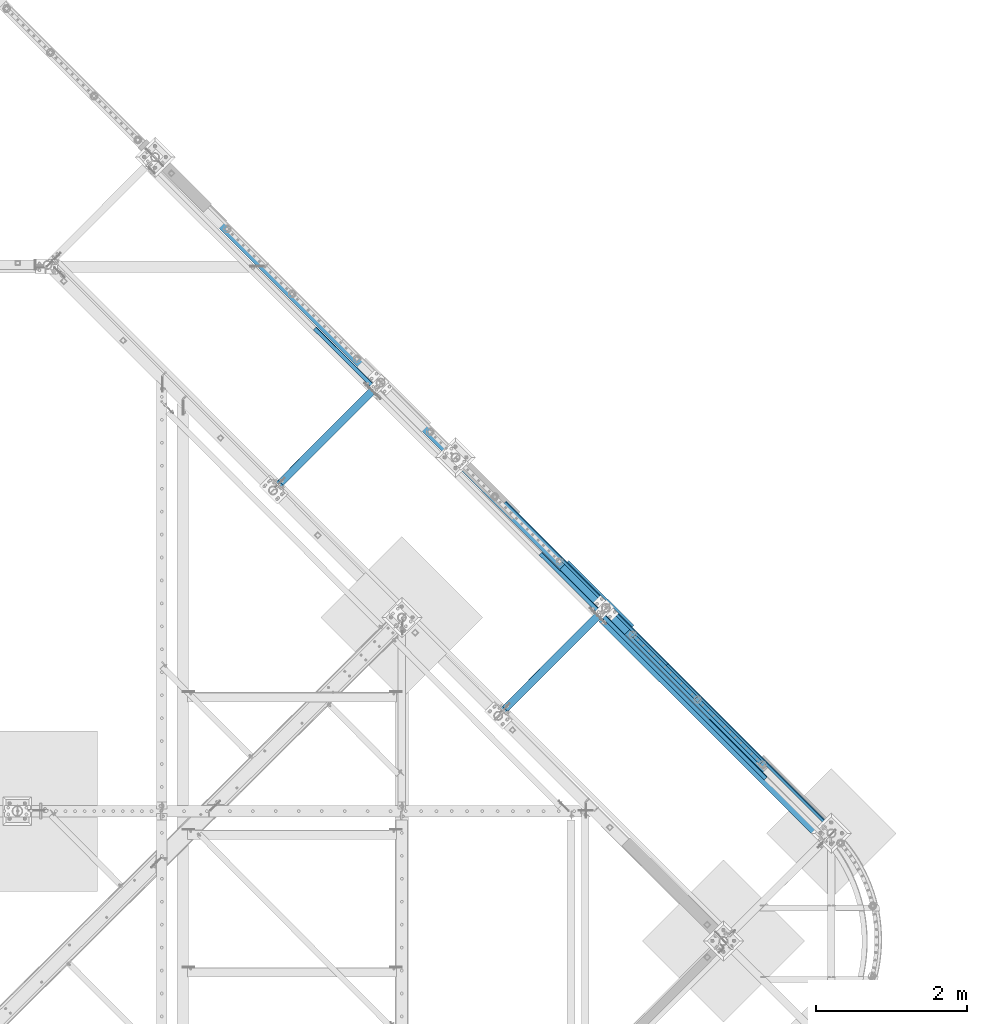
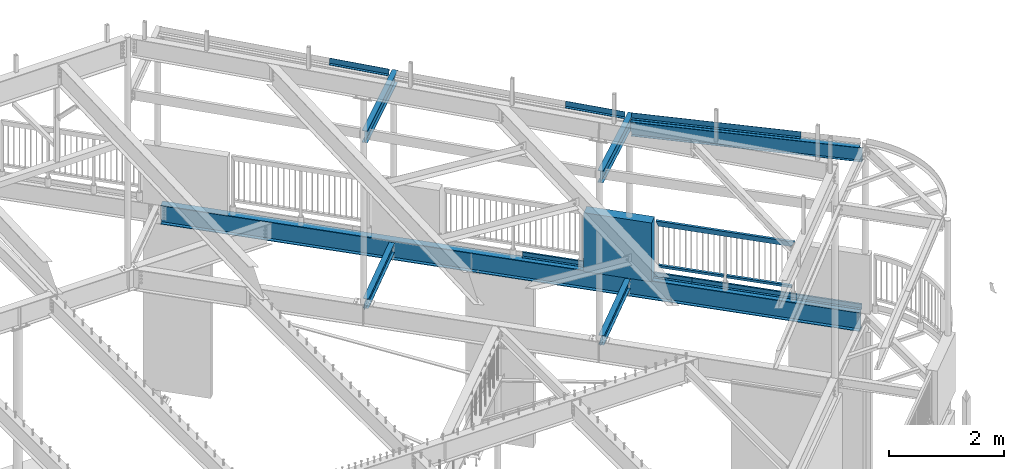
# One storey, part 374 of 975: 15 beams.
"""IFC2X3 building model written with IfcOpenShell, lengths in millimetres."""

import ifcopenshell
import ifcopenshell.guid

model = None  # the IFC model being written
_history = None  # IfcOwnerHistory: only IFC2X3 demands one
_inside = {}  # id of a spatial element -> (the spatial element, [elements in it])
_under = {}  # id of a project, library or spatial element -> (it, [spatial elements below it])
_declared = {}  # id of a project -> (the project, [libraries it declares])
_typed = {}  # id of a type object -> (the type object, [elements of that type])
_made_of = {}  # id of a material, layer set ... -> (it, [elements and type objects made of it])


def new_model(schema):
    """Start an empty IFC model of exactly this schema.

    Asked for "IFC4X3", IfcOpenShell would pick the latest addendum, in which some entities
    have other attributes; the version numbers below select the first issue.
    IFC2X3 requires an IfcOwnerHistory on every rooted entity: one is made here for all.
    """
    global model, _history
    if schema == "IFC4X3":
        model = ifcopenshell.file(schema_version=(4, 3, 0, 0))
    else:
        model = ifcopenshell.file(schema=schema)
    _inside.clear()
    _under.clear()
    _declared.clear()
    _typed.clear()
    _made_of.clear()
    _history = None
    if model.schema == "IFC2X3":
        org = make("IfcOrganization", Name="unknown")
        user = make(
            "IfcPersonAndOrganization",
            ThePerson=make("IfcPerson", FamilyName="unknown"),
            TheOrganization=org,
        )
        app = make(
            "IfcApplication",
            ApplicationDeveloper=org,
            Version="unknown",
            ApplicationFullName="unknown",
            ApplicationIdentifier="unknown",
        )
        _history = make(
            "IfcOwnerHistory",
            OwningUser=user,
            OwningApplication=app,
            ChangeAction="ADDED",
            CreationDate=0,
        )
    return model


def make(cls, **values):
    """One entity of the class cls with the attributes given. An attribute that is None is left unset."""
    return model.create_entity(
        cls, **{name: value for name, value in values.items() if value is not None}
    )


def rooted(cls, **values):
    """An entity with a GlobalId (a new one), such as an element, a storey or a relation."""
    return make(cls, GlobalId=ifcopenshell.guid.new(), OwnerHistory=_history, **values)


def si_unit(unit_type, name, prefix=None):
    """IfcSIUnit, for example si_unit("LENGTHUNIT", "METRE", prefix="MILLI")."""
    return make("IfcSIUnit", UnitType=unit_type, Prefix=prefix, Name=name)


def assignment(units):
    """IfcUnitAssignment: the units of a project."""
    return None if units is None else make("IfcUnitAssignment", Units=units)


def point(xyz):
    """IfcCartesianPoint."""
    return None if xyz is None else make("IfcCartesianPoint", Coordinates=xyz)


def direction(xyz):
    """IfcDirection."""
    return None if xyz is None else make("IfcDirection", DirectionRatios=xyz)


def frame(location, z_axis=None, x_axis=None):
    """IfcAxis2Placement3D, a coordinate frame: its origin and axes. An axis left out is left unset."""
    return make(
        "IfcAxis2Placement3D",
        Location=point(location),
        Axis=direction(z_axis),
        RefDirection=direction(x_axis),
    )


def origin_with_axes():
    """The frame at (0, 0, 0) with the z axis (0, 0, 1) and the x axis (1, 0, 0) written out."""
    return frame((0.0, 0.0, 0.0), z_axis=(0.0, 0.0, 1.0), x_axis=(1.0, 0.0, 0.0))


def place(relative_to, where):
    """IfcLocalPlacement: puts the frame where relative to a parent placement (None: the world)."""
    return make(
        "IfcLocalPlacement", PlacementRelTo=relative_to, RelativePlacement=where
    )


def context(
    kind, dimensions, precision=None, world=None, true_north=None, identifier=None
):
    """IfcGeometricRepresentationContext, for example the 3D "Model" context."""
    return make(
        "IfcGeometricRepresentationContext",
        ContextIdentifier=identifier,
        ContextType=kind,
        CoordinateSpaceDimension=dimensions,
        Precision=precision,
        WorldCoordinateSystem=world,
        TrueNorth=true_north,
    )


def subcontext(parent, identifier, kind, view, scale=None):
    """IfcGeometricRepresentationSubContext, for example "Body" below "Model"."""
    return make(
        "IfcGeometricRepresentationSubContext",
        ContextIdentifier=identifier,
        ContextType=kind,
        ParentContext=parent,
        TargetScale=scale,
        TargetView=view,
    )


def project(units=None, contexts=None):
    """IfcProject with its units and contexts."""
    return rooted(
        "IfcProject",
        Name="project",
        RepresentationContexts=contexts,
        UnitsInContext=assignment(units),
    )


def spatial(cls, under=None, at=None, **own):
    """A site, building, storey or space (cls), placed at a placement, below another one or the project."""
    s = rooted(cls, ObjectPlacement=at, **own)
    if under is not None:
        _under.setdefault(under.id(), (under, []))[1].append(s)
    return s


def faces_of(points, faces, orient=None, outer=None):
    """IfcFace entities. A face is a list of loops; a loop is a list of indices into points, from 0.

    orient and outer hold one flag for each loop. By default every Orientation is true, the
    first loop of a face is its IfcFaceOuterBound and the others are IfcFaceBound.
    """
    made = []
    for i, loops in enumerate(faces):
        bounds = []
        for j, loop in enumerate(loops):
            is_outer = j == 0 if outer is None else outer[i][j]
            bounds.append(
                make(
                    "IfcFaceOuterBound" if is_outer else "IfcFaceBound",
                    Bound=make("IfcPolyLoop", Polygon=[points[k] for k in loop]),
                    Orientation=True if orient is None else orient[i][j],
                )
            )
        made.append(make("IfcFace", Bounds=bounds))
    return made


def faceted_brep(points, faces, orient=None, outer=None, voids=None):
    """IfcFacetedBrep: a solid bounded by flat faces; with voids (closed shells), ...WithVoids."""
    shared = [point(p) for p in points]
    hull = make("IfcClosedShell", CfsFaces=faces_of(shared, faces, orient, outer))
    if voids is None:
        return make("IfcFacetedBrep", Outer=hull)
    return make(
        "IfcFacetedBrepWithVoids",
        Outer=hull,
        Voids=[
            make(cls, CfsFaces=faces_of(shared, fs, o, b)) for cls, fs, o, b in voids
        ],
    )


def shape(context_of_items, identifier, shape_type, items):
    """IfcShapeRepresentation: the items that make up one representation, for example the "Body"."""
    return make(
        "IfcShapeRepresentation",
        ContextOfItems=context_of_items,
        RepresentationIdentifier=identifier,
        RepresentationType=shape_type,
        Items=items,
    )


def material(Name=None, Category=None):
    """IfcMaterial."""
    return make("IfcMaterial", Name=Name, Category=Category)


def made_of(thing, what):
    """Note that an element or type object is made of a material, layer set ...; save() writes the relation."""
    if what is not None:
        _made_of.setdefault(what.id(), (what, []))[1].append(thing)
    return thing


def type_object(cls, material=None, **own):
    """A type object (cls), such as IfcWallType, which elements share."""
    return made_of(rooted(cls, **own), material)


def element(
    cls,
    number,
    at=None,
    inside=None,
    cuts=None,
    type_object=None,
    material=None,
    context=None,
    identifier="Body",
    shape_type=None,
    held_by="IfcProductDefinitionShape",
    body=None,
    shapes=None,
    **own,
):
    """One element of the class cls, such as IfcWall. Its Tag is "e" and its number.

    at: its placement. inside: the storey or other place that contains it. cuts: it is an
    opening in that element (IfcRelVoidsElement). A single representation is given by context,
    identifier, shape_type and body (its items); several are given by shapes. held_by: the class
    of the entity that holds the representations. save() writes the other relations.
    """
    e = rooted(cls, Tag="e%d" % number, ObjectPlacement=at, **own)
    if body is not None:
        shapes = [shape(context, identifier, shape_type, body)]
    if shapes is not None:
        e.Representation = make(held_by, Representations=shapes)
    if inside is not None:
        _inside.setdefault(inside.id(), (inside, []))[1].append(e)
    if cuts is not None:
        rooted(
            "IfcRelVoidsElement", RelatingBuildingElement=cuts, RelatedOpeningElement=e
        )
    if type_object is not None:
        _typed.setdefault(type_object.id(), (type_object, []))[1].append(e)
    return made_of(e, material)


def aggregate(whole, parts):
    """IfcRelAggregates: a whole, such as a stair, and the parts it consists of."""
    return rooted("IfcRelAggregates", RelatingObject=whole, RelatedObjects=parts)


def save(model, path):
    """Write the relations noted so far, then the file.

    IfcRelAggregates (storeys below a building ...), IfcRelContainedInSpatialStructure (elements
    in a storey), IfcRelDefinesByType, IfcRelAssociatesMaterial and IfcRelDeclares: one each for
    every whole, place, type object, material and project.
    """
    for whole, parts in _under.values():
        aggregate(whole, parts)
    for where, things in _inside.values():
        rooted(
            "IfcRelContainedInSpatialStructure",
            RelatedElements=things,
            RelatingStructure=where,
        )
    for kind, things in _typed.values():
        rooted("IfcRelDefinesByType", RelatedObjects=things, RelatingType=kind)
    for what, things in _made_of.values():
        rooted("IfcRelAssociatesMaterial", RelatedObjects=things, RelatingMaterial=what)
    for by, libraries in _declared.values():
        rooted("IfcRelDeclares", RelatingContext=by, RelatedDefinitions=libraries)
    model.write(path)


model = new_model("IFC2X3")

# Units and contexts
model_context = context("Model", 3, precision=1e-05, world=origin_with_axes())
body_context = subcontext(model_context, "Body", "Model", "MODEL_VIEW")
ifc_project = project(units=[si_unit("LENGTHUNIT", "METRE", prefix="MILLI"), si_unit("AREAUNIT", "SQUARE_METRE"), si_unit("VOLUMEUNIT", "CUBIC_METRE"), si_unit("MASSUNIT", "GRAM", prefix="KILO"), si_unit("TIMEUNIT", "SECOND"), si_unit("PLANEANGLEUNIT", "RADIAN"), si_unit("SOLIDANGLEUNIT", "STERADIAN"), si_unit("THERMODYNAMICTEMPERATUREUNIT", "DEGREE_CELSIUS"), si_unit("LUMINOUSINTENSITYUNIT", "LUMEN")], contexts=[model_context])

# Site, building, storey
site_placement = place(None, origin_with_axes())
site = spatial("IfcSite", under=ifc_project, at=site_placement, CompositionType="ELEMENT")
building_placement = place(site_placement, origin_with_axes())
building = spatial("IfcBuilding", under=site, at=building_placement, Name="Undefined", CompositionType="ELEMENT")
storey_placement = place(building_placement, origin_with_axes())
storey = spatial("IfcBuildingStorey", under=building, at=storey_placement, Name="Undefined", CompositionType="ELEMENT", Elevation=0.0)

# Beams
ifc_material_1 = material()
beam_type_1 = type_object("IfcBeamType", Name="HSS2X2X.188_TUBES", PredefinedType="NOTDEFINED")
beam_1_placement = place(storey_placement, frame((33760.7496911595, 14873.5495527709, 4229.10075294121), z_axis=(-0.707143406238003, -0.707070154237976, 0.0), x_axis=(-0.707070154237841, 0.707143406237869, -6.17000000467233e-07)))
element("IfcBeam", 1, at=beam_1_placement, inside=storey, type_object=beam_type_1, material=ifc_material_1, Name="HANDRAIL", ObjectType="HSS2X2X.188_TUBES", context=body_context, shape_type="Brep", body=[
    faceted_brep([(25.4008090784755, 20.6375000000126, -20.6375000000844), (25.4008182261714, -20.6374999999962, -20.6375000000407), (1193.80731114153, -20.6374999996497, -20.6375000016997), (1193.80733660824, 20.6375000003582, -20.6375000017506), (25.3986803055723, -20.6374999999962, 20.6375000000189), (1193.80517322093, -20.6374999996497, 20.63749999836), (25.3986711578782, 20.6375000000116, 20.6374999999753), (1193.80519868763, 20.6375000003572, 20.6374999983091), (25.4010547061143, 25.4000000000133, -25.400000000096), (25.3984234192258, 25.4000000000124, 25.3999999999724), (1193.80495494295, 25.400000000358, 25.3999999983134), (1193.80758622984, 25.400000000358, -25.4000000017622), (25.3984346779298, -25.3999999999969, 25.4000000000306), (1193.80492359932, -25.3999999996513, 25.3999999983716), (25.4010659648184, -25.3999999999969, -25.4000000000451), (1193.80755488621, -25.3999999996513, -25.400000001704)], [[[0, 1, 2, 3]], [[1, 4, 5, 2]], [[4, 6, 7, 5]], [[6, 0, 3, 7]], [[8, 9, 10, 11]], [[9, 12, 13, 10]], [[12, 14, 15, 13]], [[14, 8, 11, 15]], [[13, 15, 11, 10], [5, 7, 3, 2]], [[14, 12, 9, 8], [6, 4, 1, 0]]]),
])
beam_2_placement = place(storey_placement, frame((34622.8127198948, 14011.3972150385, 4229.10009527429), z_axis=(-0.707143406238003, -0.707070154237976, 0.0), x_axis=(-0.707070154237873, 0.7071434062379, 5.39000000270782e-07)))
element("IfcBeam", 2, at=beam_2_placement, inside=storey, type_object=beam_type_1, material=ifc_material_1, Name="HANDRAIL", ObjectType="HSS2X2X.188_TUBES", context=body_context, shape_type="Brep", body=[
    faceted_brep([(25.3959352503016, 20.6374999999971, -20.6375000000698), (25.395957497507, -20.637500000008, -20.6375000000553), (1193.80522150229, -20.6375000002545, -20.6375000017215), (1193.80516464068, 20.6374999997506, -20.637500001736), (25.3984002056568, -20.637500000008, 20.6374999999971), (1193.80308358158, -20.6375000002545, 20.6374999983382), (25.3983779584496, 20.637499999998, 20.6374999999898), (1193.80302671998, 20.6374999997506, 20.6374999983236), (25.3956508323763, 25.3999999999978, -25.4000000000815), (25.3986572424046, 25.3999999999978, 25.3999999999942), (1193.80277347587, 25.3999999997513, 25.399999998328), (1193.80540476288, 25.3999999997513, -25.4000000017404), (25.398684623583, -25.4000000000096, 25.4000000000087), (1193.80284345937, -25.4000000002561, 25.3999999983498), (25.3956782135529, -25.4000000000096, -25.4000000000597), (1193.8054747464, -25.400000000257, -25.4000000017259)], [[[0, 1, 2, 3]], [[1, 4, 5, 2]], [[4, 6, 7, 5]], [[6, 0, 3, 7]], [[8, 9, 10, 11]], [[9, 12, 13, 10]], [[12, 14, 15, 13]], [[14, 8, 11, 15]], [[13, 15, 11, 10], [5, 7, 3, 2]], [[14, 12, 9, 8], [6, 4, 1, 0]]]),
])
beam_type_2 = type_object("IfcBeamType", Name="HSS2X4X.188_TUBES", PredefinedType="NOTDEFINED")
beam_3_placement = place(storey_placement, frame((34622.8180049084, 14011.4024791943, 5130.80000000666), z_axis=(0.0, 0.0, 1.0), x_axis=(-0.70707231784675, 0.707141242846735, 0.0)))
element("IfcBeam", 3, at=beam_3_placement, inside=storey, type_object=beam_type_2, material=ifc_material_1, Name="GUARDRAIL", ObjectType="HSS2X4X.188_TUBES", context=body_context, shape_type="Brep", body=[
    faceted_brep([(23.0198915490837, 20.6374999999994, -46.0375000000031), (23.0198915283145, -20.6374999999966, -46.0375000000085), (2415.39077695601, -20.6374999954423, -46.0375000000004), (2415.39077695595, 20.63750000453, -46.0375000000004), (-23.0198845522937, -20.6374999999985, 46.0375000000058), (2461.43052065577, -20.637499995355, 46.0375000000004), (-23.0198845315244, 20.6374999999973, 46.0375000000113), (2461.43052065571, 20.6375000046173, 46.0375000000004), (25.4012592797953, 25.399999999999, -50.8000000000029), (-25.4012522574303, 25.3999999999967, 50.800000000012), (2463.81188670914, 25.4000000046217, 50.8000000000002), (2413.00941090251, 25.4000000045271, -50.8000000000002), (-25.401252282998, -25.3999999999983, 50.8000000000056), (2463.81188670921, -25.3999999953448, 50.8000000000002), (25.401259254224, -25.399999999996, -50.8000000000102), (2413.00941090258, -25.3999999954467, -50.8000000000002)], [[[0, 1, 2, 3]], [[1, 4, 5, 2]], [[4, 6, 7, 5]], [[6, 0, 3, 7]], [[8, 9, 10, 11]], [[9, 12, 13, 10]], [[12, 14, 15, 13]], [[14, 8, 11, 15]], [[13, 15, 11, 10], [5, 7, 3, 2]], [[14, 12, 9, 8], [6, 4, 1, 0]]]),
])
ifc_material_2 = material(Name="STEEL/A36")
beam_type_3 = type_object("IfcBeamType", PredefinedType="NOTDEFINED")
for number, where, z_axis, x_axis, name in (
    (4, (34418.3573434165, 14243.2724831938, 3938.58749694824), (0.707106781186513, -0.707106781186582, 3.1377567211166e-14), (0.707106781186548, 0.707106781186548, 0.0), "DECK_EDGE"),
    (5, (32263.1276564165, 16398.5021701938, 3938.58749694824), (0.707106781186513, -0.707106781186582, 3.1377567211166e-14), (0.707106781186548, 0.707106781186548, 0.0), "DECK_EDGE"),
):
    element("IfcBeam", number, at=place(storey_placement, frame(where, z_axis=z_axis, x_axis=x_axis)), inside=storey, type_object=beam_type_3, material=ifc_material_2, Name=name, context=body_context, shape_type="Brep", body=[
        faceted_brep([(1.03318598121405e-09, -1.58750000000009, -1524.00000000109), (-1.04046193882823e-09, -1.58750000000009, 1524.0000000011), (-1.04046193882823e-09, 1.58750000000009, 1524.0000000011), (1.03318598121405e-09, 1.58750000000009, -1524.00000000109), (47.6250001214066, 1.58750000000009, 1524.00000000113), (47.6250001235167, 1.58750000000009, -1524.00000000107), (50.8000001235196, -1.58750000000009, -1524.00000000106), (50.8000001214168, -1.58750000000009, 1524.00000000113), (47.6250001214503, 96.837499999901, 1524.00000000113), (47.625000123473, 96.8374999999951, -1524.00000000106), (50.8000001234759, 104.502628762961, -1524.00000000106), (50.8000001214605, 104.502628762867, 1524.00000000113), (38.6447461584321, 87.8572448731024, 1524.00000000113), (38.6447461604548, 87.8572448731024, -1524.00000000107), (36.3996819826862, 90.102308757891, 1524.00000000112), (36.3996819847016, 90.102308757891, -1524.00000000107)], [[[0, 1, 2, 3]], [[3, 2, 4, 5]], [[1, 0, 6, 7]], [[5, 4, 8, 9]], [[7, 6, 10, 11]], [[9, 8, 12, 13]], [[8, 4, 2, 1, 7, 11, 14, 12]], [[11, 10, 15, 14]], [[10, 6, 0, 3, 5, 9, 13, 15]], [[14, 15, 13, 12]]]),
    ])
beam_type_4 = type_object("IfcBeamType", PredefinedType="NOTDEFINED")
beam_4_placement = place(storey_placement, frame((33570.6862339713, 14881.9659334199, 7394.28519414579), z_axis=(0.707081767936129, -0.705506028102773, 0.047923040001313), x_axis=(0.706317608795658, 0.70789507379521, -1.28799999784181e-06)))
element("IfcBeam", 6, at=beam_4_placement, inside=storey, type_object=beam_type_4, material=ifc_material_2, Name="DECK_EDGE", context=body_context, shape_type="Brep", body=[
    faceted_brep([(-1.44573277793825e-08, -3.17500000027667, -1523.99999999641), (7.79618858359754e-09, -3.17499999972461, 1523.99999999641), (1.44573277793825e-08, 3.17500000027576, 1523.99999999641), (-7.79255060479045e-09, 3.17499999972188, -1523.9999999964), (51.3282235099323, 3.17500000138443, 1523.99999999883), (51.3282235078514, 3.17500000009932, -1523.99999999884), (57.6782232685582, -3.17499999981101, -1523.99999999882), (57.6782232706391, -3.17499999852589, 1523.99999999885), (51.3282275774545, 111.125003231497, 1523.99999999851), (51.3282275765887, 111.125003228997, -1523.99999999916), (57.6782275774676, 111.125002992181, 1523.99999999851), (57.6782275766018, 111.125002989683, -1523.99999999917)], [[[0, 1, 2, 3]], [[3, 2, 4, 5]], [[1, 0, 6, 7]], [[5, 4, 8, 9]], [[4, 2, 1, 7, 10, 8]], [[7, 6, 11, 10]], [[6, 0, 3, 5, 9, 11]], [[10, 11, 9, 8]]]),
])
beam_5_placement = place(storey_placement, frame((32031.0397329144, 16418.2765383718, 7337.95082379421), z_axis=(0.707509676766855, -0.705932996704191, -0.0329948699876541), x_axis=(0.706317571755026, 0.707895110754471, 0.0)))
element("IfcBeam", 7, at=beam_5_placement, inside=storey, type_object=beam_type_4, material=ifc_material_2, Name="DECK_EDGE", context=body_context, shape_type="Brep", body=[
    faceted_brep([(4.24188328906894e-09, -3.1750000001839, -531.812499999922), (3.12138581648469e-09, -3.17499999981828, 531.81249999992), (-4.23460733145475e-09, 3.17500000018299, 531.81249999992), (-3.10683390125632e-09, 3.17499999981737, -531.812499999924), (51.3282235870138, 3.17500005952843, 531.812499999938), (51.3282235879524, 3.17500005916372, -531.812499999904), (57.6782233771737, -3.1749999334952, -531.8124999999), (57.6782233762424, -3.17499993312958, 531.812499999947), (51.3282271701464, 111.12500381885, 531.812499999887), (51.3282271712742, 111.125003818303, -531.812499999956), (57.678227170145, 111.125003608058, 531.812499999889), (57.6782271712727, 111.125003607512, -531.812499999953)], [[[0, 1, 2, 3]], [[3, 2, 4, 5]], [[1, 0, 6, 7]], [[5, 4, 8, 9]], [[4, 2, 1, 7, 10, 8]], [[7, 6, 11, 10]], [[6, 0, 3, 5, 9, 11]], [[10, 11, 9, 8]]]),
])
beam_6_placement = place(storey_placement, frame((29033.9973259247, 19408.6400593541, 7481.28927387825), z_axis=(0.707357212670032, -0.705780872372475, -0.0389760680011505), x_axis=(0.706317571755026, 0.707895110754471, 0.0)))
element("IfcBeam", 8, at=beam_6_placement, inside=storey, type_object=beam_type_4, material=ifc_material_2, Name="DECK_EDGE", context=body_context, shape_type="Brep", body=[
    faceted_brep([(3.71073838323355e-09, -3.17500000010568, -534.19399999953), (3.20869730785489e-09, -3.17499999989559, 534.193999999528), (-3.70346242561936e-09, 3.17500000010568, 534.193999999527), (-3.20142135024071e-09, 3.17499999989559, -534.193999999537), (51.3282236322993, 3.17500005588954, 534.193999999509), (51.3282236322048, 3.17500005568036, -534.193999999558), (57.6782233794074, -3.17499993741876, -534.193999999554), (57.6782233794947, -3.17499993720958, 534.193999999505), (51.3282279295963, 111.125001395661, 534.193999999365), (51.3282279300984, 111.125001394859, -534.1939999997), (57.6782279296021, 111.125001142855, 534.193999999363), (57.6782279301042, 111.125001142052, -534.193999999702)], [[[0, 1, 2, 3]], [[3, 2, 4, 5]], [[1, 0, 6, 7]], [[5, 4, 8, 9]], [[4, 2, 1, 7, 10, 8]], [[7, 6, 11, 10]], [[6, 0, 3, 5, 9, 11]], [[10, 11, 9, 8]]]),
])
ifc_material_3 = material(Name="CONCRETE/5000")
beam_type_5 = type_object("IfcBeamType", PredefinedType="NOTDEFINED")
beam_7_placement = place(storey_placement, frame((31980.0867520505, 16649.0742554603, 4559.3), z_axis=(0.0, 0.0, 1.0), x_axis=(0.707901544041155, -0.706311124041062, 0.0)))
element("IfcBeam", 9, at=beam_7_placement, inside=storey, type_object=beam_type_5, material=ifc_material_3, Name="LOW WALL", context=body_context, shape_type="Brep", body=[
    faceted_brep([(8.00355337560177e-11, 101.599999999831, -622.3), (8.00355337560177e-11, 101.599999999831, 622.3), (1219.20000000123, 101.599999998936, 622.3), (1219.20000000123, 101.599999998936, -622.3), (-7.27595761418343e-11, -101.599999999831, 622.3), (1219.20000000109, -101.600000000741, 622.3), (-7.27595761418343e-11, -101.599999999831, -622.3), (1219.20000000109, -101.600000000741, -622.3)], [[[0, 1, 2, 3]], [[1, 4, 5, 2]], [[4, 6, 7, 5]], [[6, 0, 3, 7]], [[5, 7, 3, 2]], [[6, 4, 1, 0]]]),
])
ifc_material_4 = material(Name="STEEL/A992")
beam_type_6 = type_object("IfcBeamType", Name="W8X10", PredefinedType="NOTDEFINED")
beam_8_placement = place(storey_placement, frame((31123.3007007432, 14669.0350746867, 3836.9875), z_axis=(0.0, 0.0, 1.0), x_axis=(0.706311124041062, 0.707901544041155, 0.0)))
element("IfcBeam", 10, at=beam_8_placement, inside=storey, type_object=beam_type_6, material=ifc_material_4, Name="BEAM", ObjectType="W8X10", context=body_context, shape_type="Brep", body=[
    faceted_brep([(26.8893750067946, -2.38125000001492, -74.6125000000006), (26.8893750067946, 2.38124999997672, -74.6125000000006), (103.089372353083, 2.38124999992215, -74.6125000000006), (103.089372353079, -2.3812500000713, -74.6125000000006), (107.949451871144, 2.38124999992033, -75.5792299225886), (107.949451871144, -2.38125000007494, -75.5792299225886), (112.069628339304, 2.38124999991487, -78.3322438230666), (112.069628339304, -2.38125000007676, -78.3322438230666), (114.822642239789, 2.38124999991305, -82.4524202912203), (114.822642239789, -2.3812500000804, -82.4524202912203), (115.78937216238, -2.38125000007858, -87.3124998092658), (115.789372162384, 2.38124999991305, -87.3124998092658), (115.789372162384, 2.38124999991305, -95.25), (115.78937216242, 50.7999999998337, -95.25), (115.78937216242, 50.7999999998337, -100.0125), (115.789372162344, -50.8000000000011, -100.0125), (115.789372162344, -50.8000000000011, -95.25), (115.78937216238, -2.38125000007858, -95.25), (1892.2887837638, 50.7999999985186, 95.25), (1892.28878376376, 2.3812499985961, 95.25), (115.789375016884, 2.38124999991123, 95.25), (115.789375016924, 50.7999999998337, 95.25), (103.089375207579, -2.3812500000713, 74.6124999999993), (103.089375207586, 2.38124999992033, 74.6124999999993), (26.8893750067946, 2.38124999997672, 74.6124999999993), (26.8893750067946, -2.38125000001492, 74.6124999999993), (107.94945472564, -2.38125000007312, 75.5792299225873), (107.949454725647, 2.38124999992033, 75.5792299225873), (112.069631193808, -2.38125000007858, 78.3322438230653), (112.069631193808, 2.38124999991487, 78.3322438230653), (114.822645094289, -2.38125000007676, 82.4524202912189), (114.822645094297, 2.38124999991305, 82.4524202912189), (115.789375016884, -2.3812500000804, 87.3124998092644), (115.789375016884, 2.38124999991305, 87.3124998092644), (1892.28878376372, -50.8000000013162, 100.0125), (1892.2887837638, 50.7999999985186, 100.0125), (115.789375016924, 50.7999999998337, 100.012499813678), (115.789375016844, -50.8000000000011, 100.0125), (1892.28878376372, -50.8000000013162, 95.25), (115.789375016844, -50.8000000000011, 95.25), (1892.28878376376, -2.38125000139553, 95.25), (115.789375016884, -2.3812500000804, 95.25), (1892.28878376376, -2.38125000139553, 87.3124998092662), (1892.28878376376, 2.3812499985961, 87.3124998092662), (1893.25551368634, -2.38125000139553, 82.4524202912207), (1893.25551368635, 2.3812499985961, 82.4524202912207), (1896.00852758684, -2.38125000139735, 78.3322438230671), (1896.00852758683, 2.38124999859428, 78.3322438230671), (1900.128704055, -2.38125000139917, 75.5792299225891), (1900.128704055, 2.38124999859247, 75.5792299225891), (1904.98878357306, -2.38125000140462, 74.6125000000011), (1904.98878357306, 2.38124999858883, 74.6125000000011), (1981.18878375726, -2.38125000145737, 74.6125000000011), (1981.18878375726, 2.38124999853244, 74.6125000000011), (1981.18878375726, -2.38125000145737, -74.6124999999988), (1981.18878375726, 2.38124999853244, -74.6124999999988), (1904.98878357323, -2.38125000140462, -74.6124999999988), (1904.98878357323, 2.38124999858883, -74.6124999999988), (1900.12870405517, -2.38125000139917, -75.5792299225868), (1900.12870405517, 2.38124999859247, -75.5792299225868), (1896.008527587, -2.38125000139735, -78.3322438230648), (1896.00852758701, 2.38124999859428, -78.3322438230648), (1893.25551368652, -2.38125000139189, -82.4524202912185), (1893.25551368652, 2.3812499985961, -82.4524202912185), (1892.28878376393, -2.38125000139553, -87.312499809264), (1892.28878376393, 2.3812499985961, -87.312499809264), (1892.28878376393, -2.38125000139553, -95.25), (1892.28878376389, -50.8000000013162, -95.25), (1892.28878376389, -50.8000000013162, -100.0125), (1892.28878376396, 50.7999999985186, -100.0125), (1892.28878376396, 50.7999999985186, -95.25), (1892.28878376394, 2.38124999859792, -95.25)], [[[0, 1, 2, 3]], [[3, 2, 4, 5]], [[5, 4, 6, 7]], [[7, 6, 8, 9]], [[10, 11, 12, 13, 14, 15, 16, 17]], [[9, 8, 11, 10]], [[18, 19, 20, 21]], [[22, 23, 24, 25]], [[26, 27, 23, 22]], [[28, 29, 27, 26]], [[30, 31, 29, 28]], [[32, 33, 31, 30]], [[34, 35, 36, 37]], [[38, 34, 37, 39]], [[40, 38, 39, 41]], [[37, 36, 21, 20, 33, 32, 41, 39]], [[35, 18, 21, 36]], [[34, 38, 40, 42, 43, 19, 18, 35]], [[44, 45, 43, 42]], [[46, 47, 45, 44]], [[48, 49, 47, 46]], [[50, 51, 49, 48]], [[52, 53, 51, 50]], [[53, 52, 54, 55]], [[54, 56, 57, 55]], [[58, 59, 57, 56]], [[60, 61, 59, 58]], [[62, 63, 61, 60]], [[64, 65, 63, 62]], [[66, 67, 68, 69, 70, 71, 65, 64]], [[67, 66, 17, 16]], [[68, 67, 16, 15]], [[69, 68, 15, 14]], [[70, 69, 14, 13]], [[71, 70, 13, 12]], [[6, 4, 2, 1, 24, 23, 27, 29, 31, 33, 20, 19, 43, 45, 47, 49, 51, 53, 55, 57, 59, 61, 63, 65, 71, 12, 11, 8]], [[25, 24, 1, 0]], [[66, 64, 62, 60, 58, 56, 54, 52, 50, 48, 46, 44, 42, 40, 41, 32, 30, 28, 26, 22, 25, 0, 3, 5, 7, 9, 10, 17]]]),
])
beam_9_placement = place(storey_placement, frame((28127.7454585231, 17657.9607107225, 3836.9875), z_axis=(0.0, 0.0, 1.0), x_axis=(0.706311124041062, 0.707901544041155, 0.0)))
element("IfcBeam", 11, at=beam_9_placement, inside=storey, type_object=beam_type_6, material=ifc_material_4, Name="BEAM", ObjectType="W8X10", context=body_context, shape_type="Brep", body=[
    faceted_brep([(44.1201965405089, -2.38125000008313, -74.6125000000006), (44.1201965405089, 2.38124999991396, -74.6125000000006), (120.320196744404, 2.38124999975935, -74.6125000000006), (120.320196744397, -2.38125000023956, -74.6125000000006), (125.180276262447, 2.38124999975389, -75.5792299225886), (125.180276262439, -2.38125000024866, -75.5792299225886), (129.300452730597, 2.38124999974116, -78.3322438230666), (129.300452730586, -2.38125000025775, -78.3322438230666), (132.05346663107, 2.38124999973388, -82.4524202912203), (132.053466631063, -2.38125000026139, -82.4524202912203), (133.020196553647, -2.38125000026139, -87.3124998092658), (133.020196553658, 2.38124999973752, -87.3124998092658), (133.020196553658, 2.38124999973752, -95.25), (133.020196553756, 50.7999999997182, -95.25), (133.020196553756, 50.7999999997182, -100.0125), (133.020196553549, -50.8000000002457, -100.0125), (133.020196553549, -50.8000000002457, -95.25), (133.020196553647, -2.38125000026139, -95.25), (1896.97662620574, 50.7999999961476, 95.25), (1896.97662620564, 2.38124999616502, 95.25), (133.020196553654, 2.38124999973388, 95.25), (133.020196553749, 50.7999999997201, 95.25), (120.320196744389, -2.38125000023956, 74.6124999999993), (120.3201967444, 2.38124999975935, 74.6124999999993), (44.1201965405089, 2.38124999991396, 74.6124999999993), (44.1201965405089, -2.38125000008313, 74.6124999999993), (125.180276262436, -2.38125000024684, 75.5792299225873), (125.180276262439, 2.38124999975207, 75.5792299225873), (129.300452730582, -2.38125000025775, 78.3322438230653), (129.300452730589, 2.38124999974116, 78.3322438230653), (132.053466631056, -2.38125000026139, 82.4524202912189), (132.053466631063, 2.3812499997357, 82.4524202912189), (133.02019655364, -2.38125000026139, 87.3124998092644), (133.020196553654, 2.38124999973388, 87.3124998092644), (1896.97662620553, -50.8000000038182, 100.0125), (1896.97662620574, 50.7999999961476, 100.0125), (133.020196553749, 50.7999999997201, 100.012499813708), (133.020196553545, -50.8000000002494, 100.0125), (1896.97662620553, -50.8000000038182, 95.25), (133.020196553545, -50.8000000002494, 95.25), (1896.97662620564, -2.38125000383388, 95.25), (133.02019655364, -2.38125000026139, 95.25), (1896.97662620564, -2.38125000383388, 87.3124998092662), (1896.97662620564, 2.38124999616502, 87.3124998092662), (1897.94335612822, -2.38125000383388, 82.4524202912207), (1897.94335612823, 2.38124999616502, 82.4524202912207), (1900.69637002869, -2.38125000383934, 78.3322438230671), (1900.6963700287, 2.38124999615957, 78.3322438230671), (1904.81654649685, -2.38125000384844, 75.5792299225891), (1904.81654649686, 2.38124999614865, 75.5792299225891), (1909.67662601488, -2.38125000385935, 74.6125000000011), (1909.67662601489, 2.38124999613956, 74.6125000000011), (1985.87662621686, -2.38125000401578, 74.6125000000011), (1985.87662621686, 2.38124999598494, 74.6125000000011), (1985.87662621686, -2.38125000401578, -74.6124999999988), (1985.87662621686, 2.38124999598494, -74.6124999999988), (1909.67662601483, -2.38125000385935, -74.6124999999988), (1909.67662601484, 2.38124999613774, -74.6124999999988), (1904.81654649679, -2.38125000385025, -75.5792299225868), (1904.8165464968, 2.38124999614865, -75.5792299225868), (1900.69637002864, -2.38125000384116, -78.3322438230648), (1900.69637002865, 2.38124999615775, -78.3322438230648), (1897.94335612816, -2.38125000383752, -82.4524202912185), (1897.94335612818, 2.38124999616321, -82.4524202912185), (1896.97662620558, -2.38125000383388, -87.312499809264), (1896.97662620559, 2.38124999616502, -87.312499809264), (1896.97662620558, -2.38125000383388, -95.25), (1896.97662620548, -50.8000000038146, -95.25), (1896.97662620548, -50.8000000038146, -100.0125), (1896.97662620568, 50.7999999961476, -100.0125), (1896.97662620568, 50.7999999961476, -95.25), (1896.97662620559, 2.38124999616502, -95.25)], [[[0, 1, 2, 3]], [[3, 2, 4, 5]], [[5, 4, 6, 7]], [[7, 6, 8, 9]], [[10, 11, 12, 13, 14, 15, 16, 17]], [[9, 8, 11, 10]], [[18, 19, 20, 21]], [[22, 23, 24, 25]], [[26, 27, 23, 22]], [[28, 29, 27, 26]], [[30, 31, 29, 28]], [[32, 33, 31, 30]], [[34, 35, 36, 37]], [[38, 34, 37, 39]], [[40, 38, 39, 41]], [[37, 36, 21, 20, 33, 32, 41, 39]], [[35, 18, 21, 36]], [[34, 38, 40, 42, 43, 19, 18, 35]], [[44, 45, 43, 42]], [[46, 47, 45, 44]], [[48, 49, 47, 46]], [[50, 51, 49, 48]], [[52, 53, 51, 50]], [[53, 52, 54, 55]], [[54, 56, 57, 55]], [[58, 59, 57, 56]], [[60, 61, 59, 58]], [[62, 63, 61, 60]], [[64, 65, 63, 62]], [[66, 67, 68, 69, 70, 71, 65, 64]], [[67, 66, 17, 16]], [[68, 67, 16, 15]], [[69, 68, 15, 14]], [[70, 69, 14, 13]], [[71, 70, 13, 12]], [[6, 4, 2, 1, 24, 23, 27, 29, 31, 33, 20, 19, 43, 45, 47, 49, 51, 53, 55, 57, 59, 61, 63, 65, 71, 12, 11, 8]], [[25, 24, 1, 0]], [[66, 64, 62, 60, 58, 56, 54, 52, 50, 48, 46, 44, 42, 40, 41, 32, 30, 28, 26, 22, 25, 0, 3, 5, 7, 9, 10, 17]]]),
])
beam_type_7 = type_object("IfcBeamType", Name="W10X12", PredefinedType="NOTDEFINED")
beam_10_placement = place(storey_placement, frame((31106.4325530943, 14652.1243727759, 7342.5414129586), z_axis=(0.0530049213863204, 0.0531648083874861, 0.997178008912126), x_axis=(0.704048665087765, 0.706172400088029, -0.0750734210093583)))
element("IfcBeam", 12, at=beam_10_placement, inside=storey, type_object=beam_type_7, material=ifc_material_4, Name="BEAM", ObjectType="W10X12", context=body_context, shape_type="Brep", body=[
    faceted_brep([(88.4960487866701, -50.8000000000247, -120.649999999985), (88.8545977762878, -50.800000000032, -125.412499999984), (2132.0471597269, -50.7999999988551, -125.412500000461), (2132.0471597269, -50.7999999988569, -120.650000000463), (88.5691717872796, -2.38125000003311, -120.649999999965), (2132.04715972693, -2.38124999885804, -120.650000000443), (70.4026896465548, -2.38124999987667, 120.649999999925), (2132.04715972661, -2.38124999868887, 120.649999999445), (70.3295666459453, -50.7999999998719, 120.649999999907), (2132.04715972658, -50.799999998686, 120.649999999425), (69.9710176563312, -50.7999999998647, 125.412499999904), (2132.04715972657, -50.7999999986823, 125.41249999942), (70.124456083835, 50.8000000001211, 125.412499999944), (2132.04715972663, 50.8000000013053, 125.412499999462), (70.4830050734527, 50.8000000001193, 120.649999999947), (2132.04715972665, 50.8000000013035, 120.649999999467), (70.4098820728505, 2.38125000012224, 120.649999999929), (2132.04715972661, 2.38125000130822, 120.649999999445), (88.5763642135644, 2.38124999996398, -120.649999999963), (2132.04715972693, 2.38125000113905, -120.650000000442), (88.6494872141739, 50.7999999999593, -120.649999999943), (2132.04715972697, 50.8000000011361, -120.650000000422), (89.0080362037916, 50.7999999999556, -125.41249999994), (2132.04715972698, 50.8000000011343, -125.412500000421)], [[[0, 1, 2, 3]], [[4, 0, 3, 5]], [[6, 4, 5, 7]], [[8, 6, 7, 9]], [[10, 8, 9, 11]], [[12, 10, 11, 13]], [[14, 12, 13, 15]], [[16, 14, 15, 17]], [[18, 16, 17, 19]], [[20, 18, 19, 21]], [[1, 0, 4, 6, 8, 10, 12, 14, 16, 18, 20, 22]], [[1, 22, 23, 2]], [[19, 17, 15, 13, 11, 9, 7, 5, 3, 2, 23, 21]], [[22, 20, 21, 23]]]),
])
beam_11_placement = place(storey_placement, frame((28117.3010331057, 17647.8568574346, 7418.50841026012), z_axis=(0.0310122847115927, 0.031072652711031, 0.999035899480327), x_axis=(0.705737839227355, 0.707111611227797, -0.0439007010141426)))
element("IfcBeam", 13, at=beam_11_placement, inside=storey, type_object=beam_type_7, material=ifc_material_4, Name="BEAM", ObjectType="W10X12", context=body_context, shape_type="Brep", body=[
    faceted_brep([(80.6807122857463, -50.7999999998865, -120.650000000007), (80.8899911401822, -50.7999999998819, -125.412500000004), (2118.65175405326, -50.8000000004058, -125.412500000826), (2118.65175405324, -50.8000000004113, -120.650000000829), (80.727837274022, -2.38124999991851, -120.649999999994), (2118.6517540532, -2.38125000044147, -120.650000000818), (70.1243753157687, -2.38125000012315, 120.649999999936), (2118.6517540529, -2.38125000064701, 120.649999999108), (70.0772503275002, -50.800000000092, 120.649999999925), (2118.65175405295, -50.8000000006168, 120.649999999097), (69.8679714730606, -50.8000000000966, 125.412499999924), (2118.65175405295, -50.8000000006223, 125.412499999098), (69.9668566943546, 50.7999999998447, 125.412499999946), (2118.65175405284, 50.7999999993162, 125.41249999912), (70.1761355487979, 50.7999999998492, 120.649999999949), (2118.65175405285, 50.7999999993199, 120.649999999123), (70.1290105605221, 2.38124999987394, 120.649999999938), (2118.65175405289, 2.38124999935008, 120.649999999112), (80.7324725187646, 2.38125000007858, -120.649999999992), (2118.65175405319, 2.38124999955562, -120.650000000816), (80.7795975070439, 50.8000000000475, -120.649999999983), (2118.65175405314, 50.7999999995291, -120.650000000805), (80.9888763614799, 50.800000000052, -125.412499999982), (2118.65175405315, 50.7999999995309, -125.412500000804)], [[[0, 1, 2, 3]], [[4, 0, 3, 5]], [[6, 4, 5, 7]], [[8, 6, 7, 9]], [[10, 8, 9, 11]], [[12, 10, 11, 13]], [[14, 12, 13, 15]], [[16, 14, 15, 17]], [[18, 16, 17, 19]], [[20, 18, 19, 21]], [[1, 0, 4, 6, 8, 10, 12, 14, 16, 18, 20, 22]], [[1, 22, 23, 2]], [[19, 17, 15, 13, 11, 9, 7, 5, 3, 2, 23, 21]], [[22, 20, 21, 23]]]),
])
beam_type_8 = type_object("IfcBeamType", Name="W12X14", PredefinedType="NOTDEFINED")
beam_12_placement = place(storey_placement, frame((32446.8661114206, 15985.340917787, 7164.56077734839), z_axis=(0.0339237966755936, -0.0338492756763062, -0.998851041224517), x_axis=(0.707070528181629, -0.70551730718123, 0.0479228280123102)))
element("IfcBeam", 14, at=beam_12_placement, inside=storey, type_object=beam_type_8, material=ifc_material_4, Name="BEAM", ObjectType="W12X14", context=body_context, shape_type="Brep", body=[
    faceted_brep([(58.6225649367825, -2.38125000003492, 86.6522378049431), (58.6279146828838, 2.38124999996944, 86.6524944753528), (48.7767422891811, 2.38124999996944, 86.1798549568603), (48.7748090277328, -2.38125000003492, 86.1797622023905), (61.0265060210513, -2.38125000002765, 87.2514340768203), (61.0318557671526, 2.38124999996944, 87.2516907472282), (63.0181923428736, -2.38125000002765, 88.7249171625626), (63.0235420889803, 2.38124999997672, 88.7251738329714), (64.2944459193895, -2.38125000002765, 90.8483908841899), (64.2997956654945, 2.38124999996944, 90.8486475545978), (64.6609931942057, -2.38125000003492, 93.2986163498463), (64.6663429403088, 2.38124999996944, 93.2988730202551), (62.2113937182021, -2.38125000005675, 144.462500000087), (62.1568796972879, -50.8000000001048, 144.46250000007), (61.8531196532567, -50.800000000112, 150.812500000073), (61.9672475697898, 50.7999999999811, 150.812500000108), (62.2712697739571, 50.7999999999884, 144.462500000105), (62.2167557530447, 2.38124999994034, 144.462500000089), (59.8208525473856, -50.7999999999593, -144.462500000065), (60.1255125481675, -50.7999999999593, -150.812500000067), (4178.87596070427, -50.7999999987878, -150.812499998709), (4178.87596070426, -50.7999999987951, -144.462499998705), (60.1668503959827, 50.8000000001339, -150.812500000033), (4178.87596070424, 50.800000001298, -150.812499998674), (59.8621903952026, 50.8000000001266, -144.462500000031), (4178.87596070424, 50.8000000012908, -144.462499998671), (59.8424903271025, 2.38125000008586, -144.462500000046), (4178.87596070425, 2.38125000125001, -144.462499998687), (4215.38645851463, 2.38125000111904, 144.462500001459), (4215.28136060219, 50.8000000011598, 144.462500001476), (4214.97670060255, 50.8000000011671, 150.812500001479), (4215.19723392702, -50.7999999989261, 150.812500001444), (4215.50189392667, -50.7999999989188, 144.462500001441), (4215.39679601423, -2.38124999887805, 144.462500001458), (4228.3448459994, -2.38124999874708, -125.412500004009), (4228.33450849981, 2.38125000126456, -125.412500004008), (4191.57596051343, -2.38124999875436, -125.412500004143), (4191.57596051343, 2.38125000125001, -125.412500004144), (4186.7158809954, -2.38124999876163, -126.379229926737), (4186.7158809954, 2.38125000124273, -126.379229926735), (4182.59570452726, -2.38124999875436, -129.132243827226), (4182.59570452725, 2.38125000125001, -129.132243827225), (4179.84269062679, -2.38124999875436, -133.252420295393), (4179.84269062678, 2.38125000125001, -133.252420295393), (4178.8759607042, -2.38124999875436, -138.112499813453), (4178.87596070419, 2.38125000124273, -138.112499813451), (4178.87596070425, -2.38124999875436, -144.462499998689), (59.8405526154875, -2.38124999991851, -144.462500000048)], [[[0, 1, 2, 3]], [[4, 5, 1, 0]], [[6, 7, 5, 4]], [[8, 9, 7, 6]], [[10, 11, 9, 8]], [[12, 13, 14, 15, 16, 17, 11, 10]], [[18, 19, 20, 21]], [[19, 22, 23, 20]], [[22, 24, 25, 23]], [[24, 26, 27, 25]], [[28, 29, 30, 31, 32, 33, 34, 35]], [[34, 36, 37, 35]], [[38, 39, 37, 36]], [[40, 41, 39, 38]], [[42, 43, 41, 40]], [[44, 45, 43, 42]], [[46, 21, 20, 23, 25, 27, 45, 44]], [[47, 18, 21, 46]], [[26, 24, 22, 19, 18, 47, 3, 2]], [[28, 35, 37, 39, 41, 43, 45, 27, 26, 2, 1, 5, 7, 9, 11, 17]], [[29, 28, 17, 16]], [[30, 29, 16, 15]], [[31, 30, 15, 14]], [[32, 31, 14, 13]], [[33, 32, 13, 12]], [[6, 4, 0, 3, 47, 46, 44, 42, 40, 38, 36, 34, 33, 12, 10, 8]]]),
])
beam_type_9 = type_object("IfcBeamType", Name="W16X31", PredefinedType="NOTDEFINED")
beam_13_placement = place(storey_placement, frame((26555.6999985946, 22078.9499985781, 3735.3875), z_axis=(0.0, 0.0, 1.0), x_axis=(0.707106781186513, -0.707106781186582, 3.1377567211166e-14)))
element("IfcBeam", 15, at=beam_13_placement, inside=storey, type_object=beam_type_9, material=ifc_material_4, Name="BEAM", ObjectType="W16X31", context=body_context, shape_type="Brep", body=[
    faceted_brep([(69.8499999876681, -69.8499999998312, -190.5), (69.8499999876681, -69.8499999998312, -201.6125), (12620.0222833255, -69.8499999998312, -201.6125), (12620.0222833255, -69.8499999998312, -190.5), (69.8499999876717, -3.17499999998836, -190.5), (12620.0222833255, -3.17499999998836, -190.5), (69.8499999876717, -3.17499999998836, 190.5), (12620.0222833255, -3.17499999998836, 190.5), (69.8499999876681, -69.8499999998312, 190.5), (12620.0222833255, -69.8499999998312, 190.5), (69.8499999876681, -69.8499999998312, 201.6125), (12620.0222833255, -69.8499999998312, 201.6125), (69.8499999876699, 69.8499999998312, 201.6125), (12620.0222833255, 69.8499999998312, 201.6125), (69.8499999876699, 69.8499999998312, 190.5), (12620.0222833255, 69.8499999998312, 190.5), (69.8499999876717, 3.17499999998836, 190.5), (12620.0222833255, 3.17499999998836, 190.5), (69.8499999876717, 3.17499999998836, -190.5), (12620.0222833255, 3.17499999998836, -190.5), (69.8499999876699, 69.8499999998312, -190.5), (12620.0222833255, 69.8499999998312, -190.5), (69.8499999876699, 69.8499999998312, -201.6125), (12620.0222833255, 69.8499999998312, -201.6125)], [[[0, 1, 2, 3]], [[4, 0, 3, 5]], [[6, 4, 5, 7]], [[8, 6, 7, 9]], [[10, 8, 9, 11]], [[12, 10, 11, 13]], [[14, 12, 13, 15]], [[16, 14, 15, 17]], [[18, 16, 17, 19]], [[20, 18, 19, 21]], [[1, 0, 4, 6, 8, 10, 12, 14, 16, 18, 20, 22]], [[1, 22, 23, 2]], [[19, 17, 15, 13, 11, 9, 7, 5, 3, 2, 23, 21]], [[22, 20, 21, 23]]]),
])

save(model, "model.ifc")
